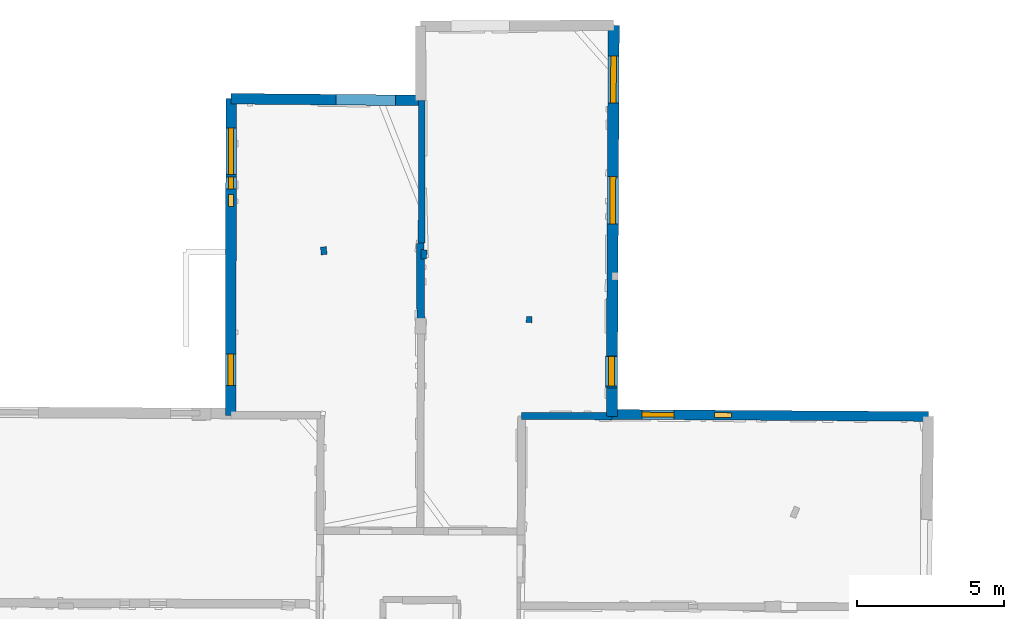
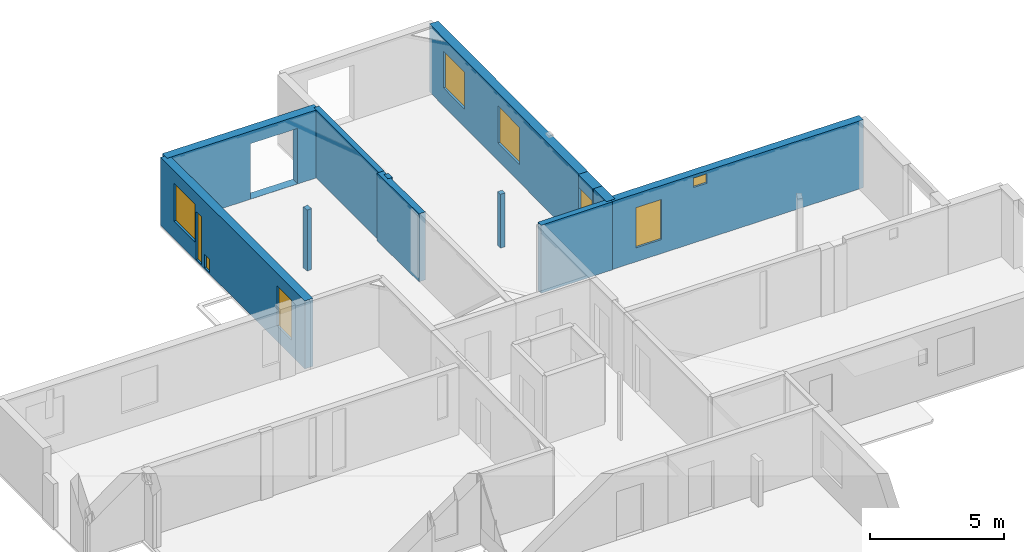
# One storey, part 12 of 17: 12 walls, 9 windows, 10 openings.
"""IFC2X3 building model written with IfcOpenShell, lengths in metres."""

from ifc_helpers import new_model, entity, si_unit, converted_unit, derived_unit, direction, frame, frame_2d, origin, origin_2d_with_axis, place, context, subcontext, project, spatial, polyline, rectangle, outline, extrude, clip, halfspace, source, transform, mapped, material, layer, layer_set, layer_usage, type_object, type_shapes, element, fill, save


model = new_model("IFC2X3")

# Units and contexts
model_context = context("Model", 3, precision=1e-05, world=origin(), true_north=direction((0.0, 1.0)))
body_context = subcontext(model_context, "Body", "Model", "MODEL_VIEW")
ifc_project = project(units=[si_unit("LENGTHUNIT", "METRE"), si_unit("AREAUNIT", "SQUARE_METRE"), si_unit("VOLUMEUNIT", "CUBIC_METRE"), converted_unit("PLANEANGLEUNIT", "DEGREE", entity("IfcRatioMeasure", 0.0174532925199433), si_unit("PLANEANGLEUNIT", "RADIAN"), dimensions=[0, 0, 0, 0, 0, 0, 0]), si_unit("MASSUNIT", "GRAM", prefix="KILO"), derived_unit("MASSDENSITYUNIT", [(si_unit("MASSUNIT", "GRAM", prefix="KILO"), 1), (si_unit("LENGTHUNIT", "METRE"), -3)]), derived_unit("MOMENTOFINERTIAUNIT", [(si_unit("LENGTHUNIT", "METRE"), 4)]), si_unit("TIMEUNIT", "SECOND"), si_unit("FREQUENCYUNIT", "HERTZ"), si_unit("THERMODYNAMICTEMPERATUREUNIT", "DEGREE_CELSIUS"), derived_unit("THERMALTRANSMITTANCEUNIT", [(si_unit("MASSUNIT", "GRAM", prefix="KILO"), 1), (si_unit("THERMODYNAMICTEMPERATUREUNIT", "KELVIN"), -1), (si_unit("TIMEUNIT", "SECOND"), -3)]), derived_unit("VOLUMETRICFLOWRATEUNIT", [(si_unit("LENGTHUNIT", "METRE"), 3), (si_unit("TIMEUNIT", "SECOND"), -1)]), si_unit("ELECTRICCURRENTUNIT", "AMPERE"), si_unit("ELECTRICVOLTAGEUNIT", "VOLT"), si_unit("POWERUNIT", "WATT"), si_unit("FORCEUNIT", "NEWTON", prefix="KILO"), si_unit("ILLUMINANCEUNIT", "LUX"), si_unit("LUMINOUSFLUXUNIT", "LUMEN"), si_unit("LUMINOUSINTENSITYUNIT", "CANDELA"), derived_unit("USERDEFINED", [(si_unit("MASSUNIT", "GRAM", prefix="KILO"), -1), (si_unit("LENGTHUNIT", "METRE"), -2), (si_unit("TIMEUNIT", "SECOND"), 3), (si_unit("LUMINOUSFLUXUNIT", "LUMEN"), 1)]), derived_unit("LINEARVELOCITYUNIT", [(si_unit("LENGTHUNIT", "METRE"), 1), (si_unit("TIMEUNIT", "SECOND"), -1)]), si_unit("PRESSUREUNIT", "PASCAL"), derived_unit("USERDEFINED", [(si_unit("LENGTHUNIT", "METRE"), -2), (si_unit("MASSUNIT", "GRAM", prefix="KILO"), 1), (si_unit("TIMEUNIT", "SECOND"), -2)]), derived_unit("LINEARFORCEUNIT", [(si_unit("MASSUNIT", "GRAM", prefix="KILO"), 1), (si_unit("LENGTHUNIT", "METRE"), 1), (si_unit("TIMEUNIT", "SECOND"), -2), (si_unit("LENGTHUNIT", "METRE"), -1)]), derived_unit("PLANARFORCEUNIT", [(si_unit("MASSUNIT", "GRAM", prefix="KILO"), 1), (si_unit("LENGTHUNIT", "METRE"), 1), (si_unit("TIMEUNIT", "SECOND"), -2), (si_unit("LENGTHUNIT", "METRE"), -2)])], contexts=[model_context])

# Site, building, storey
placement = place(None, origin())
site = spatial("IfcSite", under=ifc_project, at=placement, CompositionType="ELEMENT")
building = spatial("IfcBuilding", under=site, at=placement, CompositionType="ELEMENT")
storey_placement = place(placement, frame((0.0, 0.0, 12.0782108306885)))
storey = spatial("IfcBuildingStorey", under=building, at=storey_placement, Name="Level 5", CompositionType="ELEMENT", Elevation=12.0782108306885)

# Wall, openings, windows
ifc_material_1 = material(Name="Default wall")
ifc_layer_1 = layer(ifc_material_1, 0.330000013113022)
ifc_layer_set_1 = layer_set([ifc_layer_1], Name="wall_thickness_0.3300")
ifc_layer_usage_1 = layer_usage(ifc_layer_set_1, "AXIS2", "POSITIVE", -0.165000006556511)
wall_type_1 = type_object("IfcWallType", Name="wall_thickness_0.3300", PredefinedType="STANDARD", material=ifc_layer_set_1)
wall_1_placement = place(storey_placement, frame((12.8961935893386, 64.1211516021178, 0.0), z_axis=(0.0, 0.0, 1.0), x_axis=(0.999978543946384, -0.0065506981971868, 0.0)))
wall_1 = element("IfcWallStandardCase", 1, at=wall_1_placement, inside=storey, type_object=wall_type_1, material=ifc_layer_usage_1, Name="Wall:251", ObjectType="Wall", context=body_context, shape_type="Clipping", body=[
    clip(extrude(outline(polyline([(10.7603760625837, -0.165000006556511), (10.7603760625837, 0.165000006556511), (0.0, 0.165000006556511), (0.0, -0.165000006556511), (10.7603760625837, -0.165000006556511)])), origin(), (0.0, 0.0, 1.0), 3.09134044647217), halfspace(frame((11.7736486374089, -6.54159523407543, 9.01350348246577), z_axis=(-7.80182519603176e-05, 0.389455178282323, 0.921045415830423), x_axis=(-0.999998431469033, 0.00159936550446863, -0.000760979274747706)), False)),
])
opening_1_placement = place(wall_1_placement, frame((1.02527875583809, -0.165000006556511, 0.63578987121582)))
opening_1 = element("IfcOpeningElement", 2, at=opening_1_placement, cuts=wall_1, Name="Opening : 1085 x 1825 : 224", ObjectType="Opening", context=body_context, shape_type="SweptSolid", body=[
    extrude(rectangle(XDim=1.085, YDim=1.825, at=frame_2d((0.9125, 0.5425), x_axis=(0.0, 1.0))), frame((0.0, 0.0, 0.0), z_axis=(0.0, 1.0, 0.0), x_axis=(0.0, 0.0, 1.0)), (0.0, 0.0, 1.0), 0.330000013113022),
])
opening_2_placement = place(wall_1_placement, frame((3.48954977624388, -0.165000006556511, 2.52278900146484)))
opening_2 = element("IfcOpeningElement", 3, at=opening_2_placement, cuts=wall_1, Name="Opening : 570 x 430 : 225", ObjectType="Opening", context=body_context, shape_type="SweptSolid", body=[
    extrude(rectangle(XDim=0.57, YDim=0.43, at=frame_2d((0.215, 0.285), x_axis=(0.0, 1.0))), frame((0.0, 0.0, 0.0), z_axis=(0.0, 1.0, 0.0), x_axis=(0.0, 0.0, 1.0)), (0.0, 0.0, 1.0), 0.330000013113022),
])
ifc_material_2 = material(Name="Window Default")
window_style_1 = type_object("IfcWindowStyle", Name="Window : 1085 x 1825mm", ConstructionType="NOTDEFINED", OperationType="NOTDEFINED", ParameterTakesPrecedence=False, Sizeable=False, material=ifc_material_2)
shared_shape_1 = source(origin(), body_context, "Body", "SweptSolid", [
    extrude(rectangle(XDim=0.165000006556511, YDim=1.085, at=origin_2d_with_axis()), frame((0.5425, 0.165000006556511, 0.0), z_axis=(0.0, 0.0, 1.0), x_axis=(0.0, 1.0, 0.0)), (0.0, 0.0, 1.0), 1.825),
])
type_shapes(window_style_1, [shared_shape_1])
window_1_placement = place(opening_1_placement, origin())
window_1 = element("IfcWindow", 4, at=window_1_placement, inside=storey, type_object=window_style_1, Name="Window : 1085 x 1825mm : 121", ObjectType="Window : 1085 x 1825mm", OverallHeight=1.825, OverallWidth=1.085, context=body_context, shape_type="MappedRepresentation", body=[
    mapped(shared_shape_1, transform((0.0, 0.0, 0.0), scale=1.0)),
])
fill(opening_1, window_1)
window_style_2 = type_object("IfcWindowStyle", Name="Window : 570 x 430mm", ConstructionType="NOTDEFINED", OperationType="NOTDEFINED", ParameterTakesPrecedence=False, Sizeable=False, material=ifc_material_2)
shared_shape_2 = source(origin(), body_context, "Body", "SweptSolid", [
    extrude(rectangle(XDim=0.165000006556511, YDim=0.57, at=origin_2d_with_axis()), frame((0.285, 0.165000006556511, 0.0), z_axis=(0.0, 0.0, 1.0), x_axis=(0.0, 1.0, 0.0)), (0.0, 0.0, 1.0), 0.43),
])
type_shapes(window_style_2, [shared_shape_2])
window_2_placement = place(opening_2_placement, origin())
window_2 = element("IfcWindow", 5, at=window_2_placement, inside=storey, type_object=window_style_2, Name="Window : 570 x 430mm : 122", ObjectType="Window : 570 x 430mm", OverallHeight=0.43, OverallWidth=0.57, context=body_context, shape_type="MappedRepresentation", body=[
    mapped(shared_shape_2, transform((0.0, 0.0, 0.0), scale=1.0)),
])
fill(opening_2, window_2)

# Walls
ifc_layer_2 = layer(ifc_material_1, 0.2)
ifc_layer_set_2 = layer_set([ifc_layer_2], Name="wall_thickness_0.2000")
ifc_layer_usage_2 = layer_usage(ifc_layer_set_2, "AXIS2", "POSITIVE", -0.1)
wall_type_2 = type_object("IfcWallType", Name="wall_thickness_0.2000", PredefinedType="STANDARD", material=ifc_layer_set_2)
wall_2_placement = place(storey_placement, frame((3.08754498246227, 69.818611562889, 0.0), z_axis=(0.0, 0.0, 1.0), x_axis=(0.092548712487614, -0.99570815795437, 0.0)))
element("IfcWallStandardCase", 6, at=wall_2_placement, inside=storey, type_object=wall_type_2, material=ifc_layer_usage_2, Name="Wall:267", ObjectType="Wall", context=body_context, shape_type="Clipping", body=[
    clip(extrude(outline(polyline([(0.264999947781259, -0.1), (0.264999947781259, 0.1), (0.0, 0.1), (0.0, -0.1), (0.264999947781259, -0.1)])), origin(), (0.0, 0.0, 1.0), 2.77079010009766), halfspace(frame((-6.40195157340864, -3.77405105063798, 5.79573318480268), z_axis=(-0.0374929362924423, -0.388093923062774, 0.920856876289642), x_axis=(0.0907456834665991, 0.916373842594554, 0.389902810378011)), False)),
])
wall_3_placement = place(storey_placement, frame((6.50482039305319, 69.7204009921276, 0.0), z_axis=(0.0, 0.0, 1.0), x_axis=(-0.0210112624395793, -0.999779239057651, 0.0)))
element("IfcWallStandardCase", 7, at=wall_3_placement, inside=storey, type_object=wall_type_2, material=ifc_layer_usage_2, Name="Wall:297", ObjectType="Wall", context=body_context, shape_type="Clipping", body=[
    clip(extrude(outline(polyline([(0.310004960424696, -0.1), (0.310004960424696, 0.1), (0.0, 0.1), (0.0, -0.1), (0.310004960424696, -0.1)])), origin(), (0.0, 0.0, 1.0), 3.09134044647217), halfspace(frame((-7.64717463425576, 6.15238552582678, 6.35864093399329), z_axis=(-0.00630142451364197, 0.390449276994101, 0.920602875372374), x_axis=(0.684475427126873, -0.669469953147082, 0.288623234499112)), False)),
])
wall_4_placement = place(storey_placement, frame((10.0865659504091, 67.4545564862517, 0.0), z_axis=(0.0, 0.0, 1.0), x_axis=(-0.0178048858183893, -0.999841480456274, 0.0)))
element("IfcWallStandardCase", 8, at=wall_4_placement, inside=storey, type_object=wall_type_2, material=ifc_layer_usage_2, Name="Wall:316", ObjectType="Wall", context=body_context, shape_type="Clipping", body=[
    clip(extrude(outline(polyline([(0.214999901998866, -0.1), (0.214999901998866, 0.1), (0.0, 0.1), (0.0, -0.1), (0.214999901998866, -0.1)])), origin(), (0.0, 0.0, 1.0), 2.44278907775879), halfspace(frame((-9.82911750817032, 2.55535731435317, 6.35864093399329), z_axis=(-0.0050492304346063, 0.390467477683014, 0.920602875372374), x_axis=(0.682324932866207, -0.671661607132935, 0.288623234499112)), False)),
])
ifc_layer_3 = layer(ifc_material_1, 0.239999994635582)
ifc_layer_set_3 = layer_set([ifc_layer_3], Name="wall_thickness_0.2400")
ifc_layer_usage_3 = layer_usage(ifc_layer_set_3, "AXIS2", "POSITIVE", -0.119999997317791)
wall_type_3 = type_object("IfcWallType", Name="wall_thickness_0.2400", PredefinedType="STANDARD", material=ifc_layer_set_3)
wall_5_placement = place(storey_placement, frame((9.83064184332195, 64.067386094384, 0.0), z_axis=(0.0, 0.0, 1.0), x_axis=(0.999995554336942, -0.00298182936317414, 0.0)))
element("IfcWallStandardCase", 9, at=wall_5_placement, inside=storey, type_object=wall_type_3, material=ifc_layer_usage_3, Name="Wall:281", ObjectType="Wall", context=body_context, shape_type="Clipping", body=[
    clip(clip(extrude(outline(polyline([(3.06523732085998, -0.119999997317791), (3.06523732085998, 0.119999997317791), (0.0, 0.119999997317791), (0.0, -0.119999997317791), (3.06523732085998, -0.119999997317791)])), origin(), (0.0, 0.0, 1.0), 3.09134044647217), halfspace(frame((14.8156051309226, -6.52066637070002, 9.01350348246577), z_axis=(0.00131191026780619, 0.389452976454427, 0.921045415830423), x_axis=(-0.999986354940518, 0.00516825341098856, -0.000760979274747706)), False)), halfspace(frame((2.94660098555321, 13.1780767942376, 6.35864093399329), z_axis=(0.390499422719865, -0.000739399465191122, 0.920602875372374), x_axis=(-0.681702218919891, -0.672293621289811, 0.288623234499112)), False)),
])

# Wall, openings, windows
ifc_layer_4 = layer(ifc_material_1, 0.379999995231628)
ifc_layer_set_4 = layer_set([ifc_layer_4], Name="wall_thickness_0.3800")
ifc_layer_usage_4 = layer_usage(ifc_layer_set_4, "AXIS2", "POSITIVE", -0.189999997615814)
wall_type_4 = type_object("IfcWallType", Name="wall_thickness_0.3800", PredefinedType="STANDARD", material=ifc_layer_set_4)
wall_6_placement = place(storey_placement, frame((12.9600212645619, 77.3531687393288, 0.0), z_axis=(0.0, 0.0, 1.0), x_axis=(-0.00520165537921752, -0.999986471299145, 0.0)))
wall_6 = element("IfcWallStandardCase", 10, at=wall_6_placement, inside=storey, type_object=wall_type_4, material=ifc_layer_usage_4, Name="Wall:326", ObjectType="Wall", context=body_context, shape_type="Clipping", body=[
    clip(clip(extrude(outline(polyline([(11.2398752664765, -0.189999997615814), (11.2398752664765, 0.189999997615814), (0.0, 0.189999997615814), (0.0, -0.189999997615814), (11.2398752664765, -0.189999997615814)])), origin(), (0.0, 0.0, 1.0), 3.09134044647217), halfspace(frame((-1.16864463571214, 0.629298682200182, 5.77343483799827), z_axis=(-0.395631674563833, -0.00221291662211437, 0.918406598997329), x_axis=(0.00559329192779432, -0.99998435742036, 0.0)), False)), halfspace(frame((0.117295541245191, -0.142888561060199, 6.35864093399329), z_axis=(-0.000127449857016629, 0.3905001019368, 0.920602875372374), x_axis=(0.673805236912373, -0.680208152859646, 0.288623234499112)), False)),
])
opening_3_placement = place(wall_6_placement, frame((5.14969729735994, -0.189999997615814, 0.810790061950684)))
opening_3 = element("IfcOpeningElement", 11, at=opening_3_placement, cuts=wall_6, Name="Opening : 1605 x 1685 : 269", ObjectType="Opening", context=body_context, shape_type="SweptSolid", body=[
    extrude(rectangle(XDim=1.605, YDim=1.685, at=frame_2d((0.8425, 0.8025), x_axis=(0.0, 1.0))), frame((0.0, 0.0, 0.0), z_axis=(0.0, 1.0, 0.0), x_axis=(0.0, 0.0, 1.0)), (0.0, 0.0, 1.0), 0.379999995231628),
])
opening_4_placement = place(wall_6_placement, frame((1.04969676012918, -0.189999997615814, 0.820789337158203)))
opening_4 = element("IfcOpeningElement", 12, at=opening_4_placement, cuts=wall_6, Name="Opening : 1600 x 1675 : 270", ObjectType="Opening", context=body_context, shape_type="SweptSolid", body=[
    extrude(rectangle(XDim=1.6, YDim=1.675, at=frame_2d((0.8375, 0.8), x_axis=(0.0, 1.0))), frame((0.0, 0.0, 0.0), z_axis=(0.0, 1.0, 0.0), x_axis=(0.0, 0.0, 1.0)), (0.0, 0.0, 1.0), 0.379999995231628),
])
window_style_3 = type_object("IfcWindowStyle", Name="Window : 1605 x 1685mm", ConstructionType="NOTDEFINED", OperationType="NOTDEFINED", ParameterTakesPrecedence=False, Sizeable=False, material=ifc_material_2)
shared_shape_3 = source(origin(), body_context, "Body", "SweptSolid", [
    extrude(rectangle(XDim=0.189999997615814, YDim=1.605, at=origin_2d_with_axis()), frame((0.8025, 0.189999997615814, 0.0), z_axis=(0.0, 0.0, 1.0), x_axis=(0.0, 1.0, 0.0)), (0.0, 0.0, 1.0), 1.685),
])
type_shapes(window_style_3, [shared_shape_3])
window_3_placement = place(opening_3_placement, origin())
window_3 = element("IfcWindow", 13, at=window_3_placement, inside=storey, type_object=window_style_3, Name="Window : 1605 x 1685mm : 144", ObjectType="Window : 1605 x 1685mm", OverallHeight=1.685, OverallWidth=1.605, context=body_context, shape_type="MappedRepresentation", body=[
    mapped(shared_shape_3, transform((0.0, 0.0, 0.0), scale=1.0)),
])
fill(opening_3, window_3)
window_style_4 = type_object("IfcWindowStyle", Name="Window : 1600 x 1675mm", ConstructionType="NOTDEFINED", OperationType="NOTDEFINED", ParameterTakesPrecedence=False, Sizeable=False, material=ifc_material_2)
shared_shape_4 = source(origin(), body_context, "Body", "SweptSolid", [
    extrude(rectangle(XDim=0.189999997615814, YDim=1.6, at=origin_2d_with_axis()), frame((0.8, 0.189999997615814, 0.0), z_axis=(0.0, 0.0, 1.0), x_axis=(0.0, 1.0, 0.0)), (0.0, 0.0, 1.0), 1.675),
])
type_shapes(window_style_4, [shared_shape_4])
window_4_placement = place(opening_4_placement, origin())
window_4 = element("IfcWindow", 14, at=window_4_placement, inside=storey, type_object=window_style_4, Name="Window : 1600 x 1675mm : 145", ObjectType="Window : 1600 x 1675mm", OverallHeight=1.675, OverallWidth=1.6, context=body_context, shape_type="MappedRepresentation", body=[
    mapped(shared_shape_4, transform((0.0, 0.0, 0.0), scale=1.0)),
])
fill(opening_4, window_4)

# Wall
ifc_layer_5 = layer(ifc_material_1, 0.370000004768372)
ifc_layer_set_5 = layer_set([ifc_layer_5], Name="wall_thickness_0.3700")
ifc_layer_usage_5 = layer_usage(ifc_layer_set_5, "AXIS2", "POSITIVE", -0.185000002384186)
wall_type_5 = type_object("IfcWallType", Name="wall_thickness_0.3700", PredefinedType="STANDARD", material=ifc_layer_set_5)
wall_7_placement = place(storey_placement, frame((12.9009056676189, 65.0273217622366, 0.0), z_axis=(0.0, 0.0, 1.0), x_axis=(-0.00520092320926666, -0.999986475107424, 0.0)))
element("IfcWallStandardCase", 15, at=wall_7_placement, inside=storey, type_object=wall_type_5, material=ifc_layer_usage_5, Name="Wall:328", ObjectType="Wall", context=body_context, shape_type="Clipping", body=[
    clip(clip(extrude(outline(polyline([(0.969091170818825, -0.185000002384186), (0.969091170818825, 0.185000002384186), (0.0, 0.185000002384186), (0.0, -0.185000002384186), (0.969091170818825, -0.185000002384186)])), origin(), (0.0, 0.0, 1.0), 3.09134044647217), halfspace(frame((7.46366373341824, 11.7648089867006, 9.01350348246577), z_axis=(-0.389454928806215, 0.00044766763272762, 0.921045415830423), x_axis=(-0.0029491599120002, -0.999995361672421, -0.000760979274747706)), False)), halfspace(frame((-12.2086922903911, -0.147879633147719, 6.35864093399329), z_axis=(-0.00012716394070868, 0.390500102030011, 0.920602875372374), x_axis=(0.673804738877486, -0.680208646206084, 0.288623234499112)), False)),
])

# Wall, opening
ifc_layer_6 = layer(ifc_material_1, 0.360000014305115)
ifc_layer_set_6 = layer_set([ifc_layer_6], Name="wall_thickness_0.3600")
ifc_layer_usage_6 = layer_usage(ifc_layer_set_6, "AXIS2", "POSITIVE", -0.180000007152557)
wall_type_6 = type_object("IfcWallType", Name="wall_thickness_0.3600", PredefinedType="STANDARD", material=ifc_layer_set_6)
wall_8_placement = place(storey_placement, frame((-0.0506259305802329, 74.855613656055, 0.0), z_axis=(0.0, 0.0, 1.0), x_axis=(0.999959560869867, -0.00899314321813613, 0.0)))
wall_8 = element("IfcWallStandardCase", 16, at=wall_8_placement, inside=storey, type_object=wall_type_6, material=ifc_layer_usage_6, Name="Wall:238", ObjectType="Wall", context=body_context, shape_type="Clipping", body=[
    clip(extrude(outline(polyline([(6.4848396586485, -0.180000007152557), (6.4848396586485, 0.180000007152557), (0.0, 0.180000007152557), (0.0, -0.180000007152557), (6.4848396586485, -0.180000007152557)])), origin(), (0.0, 0.0, 1.0), 3.09134044647217), halfspace(frame((13.6125233385311, 3.7854829674488, 5.77343483799827), z_axis=(-0.00371296848489958, 0.395620440300029, 0.918406598997329), x_axis=(-0.999955962086334, -0.00938476893667588, 0.0)), False)),
])
opening_5_placement = place(wall_8_placement, frame((3.57140838603006, -0.180000007152557, 0.00578975677490234)))
element("IfcOpeningElement", 17, at=opening_5_placement, cuts=wall_8, Name="Opening : 2015 x 2520 : 214", ObjectType="Opening", context=body_context, shape_type="SweptSolid", body=[
    extrude(rectangle(XDim=2.015, YDim=2.52, at=frame_2d((1.26, 1.0075), x_axis=(0.0, 1.0))), frame((0.0, 0.0, 0.0), z_axis=(0.0, 1.0, 0.0), x_axis=(0.0, 0.0, 1.0)), (0.0, 0.0, 1.0), 0.360000014305115),
])

# Wall, openings, windows
wall_9_placement = place(storey_placement, frame((-0.0506252866856641, 74.8556117698028, 0.0), z_axis=(0.0, 0.0, 1.0), x_axis=(-0.00111281704149948, -0.999999380818924, 0.0)))
wall_9 = element("IfcWallStandardCase", 18, at=wall_9_placement, inside=storey, type_object=wall_type_6, material=ifc_layer_usage_6, Name="Wall:314", ObjectType="Wall", context=body_context, shape_type="Clipping", body=[
    clip(extrude(outline(polyline([(10.7637548336586, -0.180000007152557), (10.7637548336586, 0.180000007152557), (0.0, 0.180000007152557), (0.0, -0.180000007152557), (10.7637548336586, -0.180000007152557)])), origin(), (0.0, 0.0, 1.0), 3.09134044647217), halfspace(frame((-0.986842094506706, -1.2132744519722, 5.79573318480268), z_axis=(-0.000980543381967832, -0.389899540811168, 0.920856876289642), x_axis=(0.0045222689295026, 0.920844909603706, 0.389902810378011)), False)),
])
opening_6_placement = place(wall_9_placement, frame((0.992310188896088, -0.180000007152557, 0.79578971862793)))
opening_6 = element("IfcOpeningElement", 19, at=opening_6_placement, cuts=wall_9, Name="Opening : 1585 x 1725 : 255", ObjectType="Opening", context=body_context, shape_type="SweptSolid", body=[
    extrude(rectangle(XDim=1.585, YDim=1.725, at=frame_2d((0.8625, 0.7925), x_axis=(0.0, 1.0))), frame((0.0, 0.0, 0.0), z_axis=(0.0, 1.0, 0.0), x_axis=(0.0, 0.0, 1.0)), (0.0, 0.0, 1.0), 0.360000014305115),
])
opening_7_placement = place(wall_9_placement, frame((2.65392468208876, -0.180000007152557, 0.0567893981933594)))
opening_7 = element("IfcOpeningElement", 20, at=opening_7_placement, cuts=wall_9, Name="Opening : 415 x 2175 : 256", ObjectType="Opening", context=body_context, shape_type="SweptSolid", body=[
    extrude(rectangle(XDim=0.415, YDim=2.175, at=frame_2d((1.0875, 0.2075), x_axis=(0.0, 1.0))), frame((0.0, 0.0, 0.0), z_axis=(0.0, 1.0, 0.0), x_axis=(0.0, 0.0, 1.0)), (0.0, 0.0, 1.0), 0.360000014305115),
])
opening_8_placement = place(wall_9_placement, frame((3.26393329951785, -0.180000007152557, 0.0567893981933594)))
opening_8 = element("IfcOpeningElement", 21, at=opening_8_placement, cuts=wall_9, Name="Opening : 400 x 620 : 257", ObjectType="Opening", context=body_context, shape_type="SweptSolid", body=[
    extrude(rectangle(XDim=0.4, YDim=0.62, at=frame_2d((0.31, 0.2), x_axis=(0.0, 1.0))), frame((0.0, 0.0, 0.0), z_axis=(0.0, 1.0, 0.0), x_axis=(0.0, 0.0, 1.0)), (0.0, 0.0, 1.0), 0.360000014305115),
])
opening_9_placement = place(wall_9_placement, frame((8.68231739177822, -0.180000007152557, 0.695789337158203)))
opening_9 = element("IfcOpeningElement", 22, at=opening_9_placement, cuts=wall_9, Name="Opening : 1070 x 1830 : 258", ObjectType="Opening", context=body_context, shape_type="SweptSolid", body=[
    extrude(rectangle(XDim=1.07, YDim=1.83, at=frame_2d((0.915, 0.535), x_axis=(0.0, 1.0))), frame((0.0, 0.0, 0.0), z_axis=(0.0, 1.0, 0.0), x_axis=(0.0, 0.0, 1.0)), (0.0, 0.0, 1.0), 0.360000014305115),
])
window_style_5 = type_object("IfcWindowStyle", Name="Window : 1585 x 1725mm", ConstructionType="NOTDEFINED", OperationType="NOTDEFINED", ParameterTakesPrecedence=False, Sizeable=False, material=ifc_material_2)
shared_shape_5 = source(origin(), body_context, "Body", "SweptSolid", [
    extrude(rectangle(XDim=0.180000007152557, YDim=1.585, at=origin_2d_with_axis()), frame((0.7925, 0.180000007152557, 0.0), z_axis=(0.0, 0.0, 1.0), x_axis=(0.0, 1.0, 0.0)), (0.0, 0.0, 1.0), 1.725),
])
type_shapes(window_style_5, [shared_shape_5])
window_5_placement = place(opening_6_placement, origin())
window_5 = element("IfcWindow", 23, at=window_5_placement, inside=storey, type_object=window_style_5, Name="Window : 1585 x 1725mm : 136", ObjectType="Window : 1585 x 1725mm", OverallHeight=1.725, OverallWidth=1.585, context=body_context, shape_type="MappedRepresentation", body=[
    mapped(shared_shape_5, transform((0.0, 0.0, 0.0), scale=1.0)),
])
fill(opening_6, window_5)
window_style_6 = type_object("IfcWindowStyle", Name="Window : 415 x 2175mm", ConstructionType="NOTDEFINED", OperationType="NOTDEFINED", ParameterTakesPrecedence=False, Sizeable=False, material=ifc_material_2)
shared_shape_6 = source(origin(), body_context, "Body", "SweptSolid", [
    extrude(rectangle(XDim=0.180000007152557, YDim=0.415, at=origin_2d_with_axis()), frame((0.2075, 0.180000007152557, 0.0), z_axis=(0.0, 0.0, 1.0), x_axis=(0.0, 1.0, 0.0)), (0.0, 0.0, 1.0), 2.175),
])
type_shapes(window_style_6, [shared_shape_6])
window_6_placement = place(opening_7_placement, origin())
window_6 = element("IfcWindow", 24, at=window_6_placement, inside=storey, type_object=window_style_6, Name="Window : 415 x 2175mm : 137", ObjectType="Window : 415 x 2175mm", OverallHeight=2.175, OverallWidth=0.415, context=body_context, shape_type="MappedRepresentation", body=[
    mapped(shared_shape_6, transform((0.0, 0.0, 0.0), scale=1.0)),
])
fill(opening_7, window_6)
window_style_7 = type_object("IfcWindowStyle", Name="Window : 400 x 620mm", ConstructionType="NOTDEFINED", OperationType="NOTDEFINED", ParameterTakesPrecedence=False, Sizeable=False, material=ifc_material_2)
shared_shape_7 = source(origin(), body_context, "Body", "SweptSolid", [
    extrude(rectangle(XDim=0.180000007152557, YDim=0.4, at=origin_2d_with_axis()), frame((0.2, 0.180000007152557, 0.0), z_axis=(0.0, 0.0, 1.0), x_axis=(0.0, 1.0, 0.0)), (0.0, 0.0, 1.0), 0.62),
])
type_shapes(window_style_7, [shared_shape_7])
window_7_placement = place(opening_8_placement, origin())
window_7 = element("IfcWindow", 25, at=window_7_placement, inside=storey, type_object=window_style_7, Name="Window : 400 x 620mm : 138", ObjectType="Window : 400 x 620mm", OverallHeight=0.62, OverallWidth=0.4, context=body_context, shape_type="MappedRepresentation", body=[
    mapped(shared_shape_7, transform((0.0, 0.0, 0.0), scale=1.0)),
])
fill(opening_8, window_7)
window_style_8 = type_object("IfcWindowStyle", Name="Window : 1070 x 1830mm", ConstructionType="NOTDEFINED", OperationType="NOTDEFINED", ParameterTakesPrecedence=False, Sizeable=False, material=ifc_material_2)
shared_shape_8 = source(origin(), body_context, "Body", "SweptSolid", [
    extrude(rectangle(XDim=0.180000007152557, YDim=1.07, at=origin_2d_with_axis()), frame((0.535, 0.180000007152557, 0.0), z_axis=(0.0, 0.0, 1.0), x_axis=(0.0, 1.0, 0.0)), (0.0, 0.0, 1.0), 1.83),
])
type_shapes(window_style_8, [shared_shape_8])
window_8_placement = place(opening_9_placement, origin())
window_8 = element("IfcWindow", 26, at=window_8_placement, inside=storey, type_object=window_style_8, Name="Window : 1070 x 1830mm : 139", ObjectType="Window : 1070 x 1830mm", OverallHeight=1.83, OverallWidth=1.07, context=body_context, shape_type="MappedRepresentation", body=[
    mapped(shared_shape_8, transform((0.0, 0.0, 0.0), scale=1.0)),
])
fill(opening_9, window_8)

# Walls
ifc_layer_7 = layer(ifc_material_1, 0.230000004172325)
ifc_layer_set_7 = layer_set([ifc_layer_7], Name="wall_thickness_0.2300")
ifc_layer_usage_7 = layer_usage(ifc_layer_set_7, "AXIS2", "POSITIVE", -0.115000002086163)
wall_type_7 = type_object("IfcWallType", Name="wall_thickness_0.2300", PredefinedType="STANDARD", material=ifc_layer_set_7)
wall_10_placement = place(storey_placement, frame((6.43395096257421, 74.7972955783575, 0.0), z_axis=(0.0, 0.0, 1.0), x_axis=(-0.00171647121815173, -0.999998526862193, 0.0)))
element("IfcWallStandardCase", 27, at=wall_10_placement, inside=storey, type_object=wall_type_7, material=ifc_layer_usage_7, Name="Wall:360", ObjectType="Wall", context=body_context, shape_type="Clipping", body=[
    clip(extrude(outline(polyline([(4.85373639826947, -0.115000002086163), (4.85373639826947, 0.115000002086163), (0.0, 0.115000002086163), (0.0, -0.115000002086163), (4.85373639826947, -0.115000002086163)])), origin(), (0.0, 0.0, 1.0), 3.09134044647217), halfspace(frame((-3.7335155142191, 7.15504142568936, 5.77343483799827), z_axis=(-0.395636984219699, -0.000834047780960406, 0.918406598997329), x_axis=(0.00210811275548154, -0.999997777927836, 0.0)), False)),
])
ifc_layer_8 = layer(ifc_material_1, 0.270000010728836)
ifc_layer_set_8 = layer_set([ifc_layer_8], Name="wall_thickness_0.2700")
ifc_layer_usage_8 = layer_usage(ifc_layer_set_8, "AXIS2", "POSITIVE", -0.135000005364418)
wall_type_8 = type_object("IfcWallType", Name="wall_thickness_0.2700", PredefinedType="STANDARD", material=ifc_layer_set_8)
wall_11_placement = place(storey_placement, frame((6.40248789073184, 66.861313263639, 0.0), z_axis=(0.0, 0.0, 1.0), x_axis=(-0.00763215919667827, 0.999970874648855, 0.0)))
element("IfcWallStandardCase", 28, at=wall_11_placement, inside=storey, type_object=wall_type_8, material=ifc_layer_usage_8, Name="Wall:366", ObjectType="Wall", context=body_context, shape_type="Clipping", body=[
    clip(extrude(outline(polyline([(3.08094605687795, -0.135000005364418), (3.08094605687795, 0.135000005364418), (0.0, 0.135000005364418), (0.0, -0.135000005364418), (3.08094605687795, -0.135000005364418)])), origin(), (0.0, 0.0, 1.0), 3.09134044647217), halfspace(frame((9.04073122761647, 7.59650965448071, 5.79573318480268), z_axis=(0.00439015362825271, 0.389876057153044, 0.920856876289642), x_axis=(-0.012574828664519, -0.920770151635785, 0.38990281037801)), False)),
])

# Wall, opening, window
ifc_layer_9 = layer(ifc_material_1, 0.409999996423721)
ifc_layer_set_9 = layer_set([ifc_layer_9], Name="wall_thickness_0.4100")
ifc_layer_usage_9 = layer_usage(ifc_layer_set_9, "AXIS2", "POSITIVE", -0.204999998211861)
wall_type_9 = type_object("IfcWallType", Name="wall_thickness_0.4100", PredefinedType="STANDARD", material=ifc_layer_set_9)
wall_12_placement = place(storey_placement, frame((12.886556462069, 66.1135233932221, 0.0), z_axis=(0.0, 0.0, 1.0), x_axis=(-0.0052033968958558, -0.999986462238737, 0.0)))
wall_12 = element("IfcWallStandardCase", 29, at=wall_12_placement, inside=storey, type_object=wall_type_9, material=ifc_layer_usage_9, Name="Wall:327", ObjectType="Wall", context=body_context, shape_type="Clipping", body=[
    clip(extrude(outline(polyline([(1.08611242081581, -0.204999998211861), (1.08611242081581, 0.204999998211861), (0.0, 0.204999998211861), (0.0, -0.204999998211861), (1.08611242081581, -0.204999998211861)])), origin(), (0.0, 0.0, 1.0), 3.09134044647217), halfspace(frame((-11.1225796629054, -0.127908884545561, 6.35864093399329), z_axis=(-0.00012812992864477, 0.390500101714249, 0.920602875372374), x_axis=(0.673806421521199, -0.680206979399702, 0.288623234499112)), False)),
])
opening_10_placement = place(wall_12_placement, frame((0.0298155005223704, -0.204999998211861, 0.835789680480957)))
opening_10 = element("IfcOpeningElement", 30, at=opening_10_placement, cuts=wall_12, Name="Opening : 995 x 1685 : 271", ObjectType="Opening", context=body_context, shape_type="SweptSolid", body=[
    extrude(rectangle(XDim=0.995, YDim=1.685, at=frame_2d((0.8425, 0.4975), x_axis=(0.0, 1.0))), frame((0.0, 0.0, 0.0), z_axis=(0.0, 1.0, 0.0), x_axis=(0.0, 0.0, 1.0)), (0.0, 0.0, 1.0), 0.409999996423721),
])
window_style_9 = type_object("IfcWindowStyle", Name="Window : 995 x 1685mm", ConstructionType="NOTDEFINED", OperationType="NOTDEFINED", ParameterTakesPrecedence=False, Sizeable=False, material=ifc_material_2)
shared_shape_9 = source(origin(), body_context, "Body", "SweptSolid", [
    extrude(rectangle(XDim=0.204999998211861, YDim=0.995, at=origin_2d_with_axis()), frame((0.4975, 0.204999998211861, 0.0), z_axis=(0.0, 0.0, 1.0), x_axis=(0.0, 1.0, 0.0)), (0.0, 0.0, 1.0), 1.685),
])
type_shapes(window_style_9, [shared_shape_9])
window_9_placement = place(opening_10_placement, origin())
window_9 = element("IfcWindow", 31, at=window_9_placement, inside=storey, type_object=window_style_9, Name="Window : 995 x 1685mm : 146", ObjectType="Window : 995 x 1685mm", OverallHeight=1.685, OverallWidth=0.995, context=body_context, shape_type="MappedRepresentation", body=[
    mapped(shared_shape_9, transform((0.0, 0.0, 0.0), scale=1.0)),
])
fill(opening_10, window_9)

save(model, "model.ifc")
